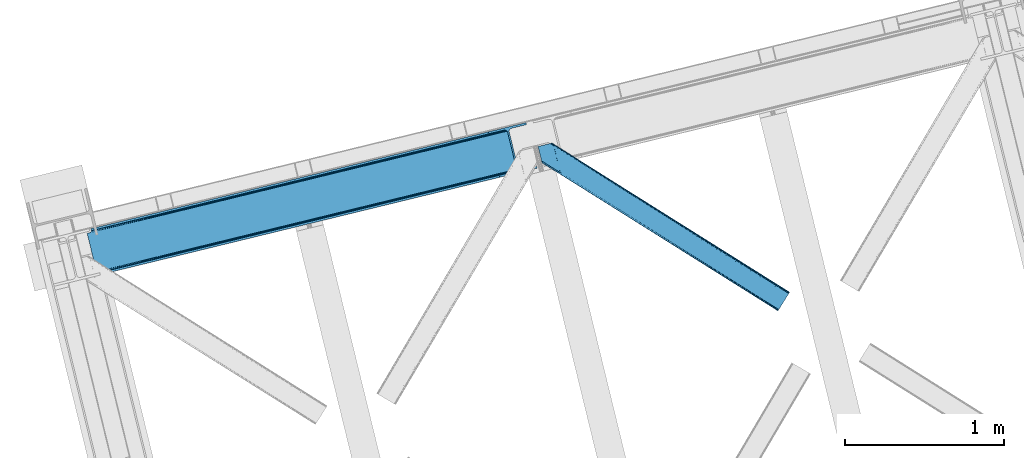
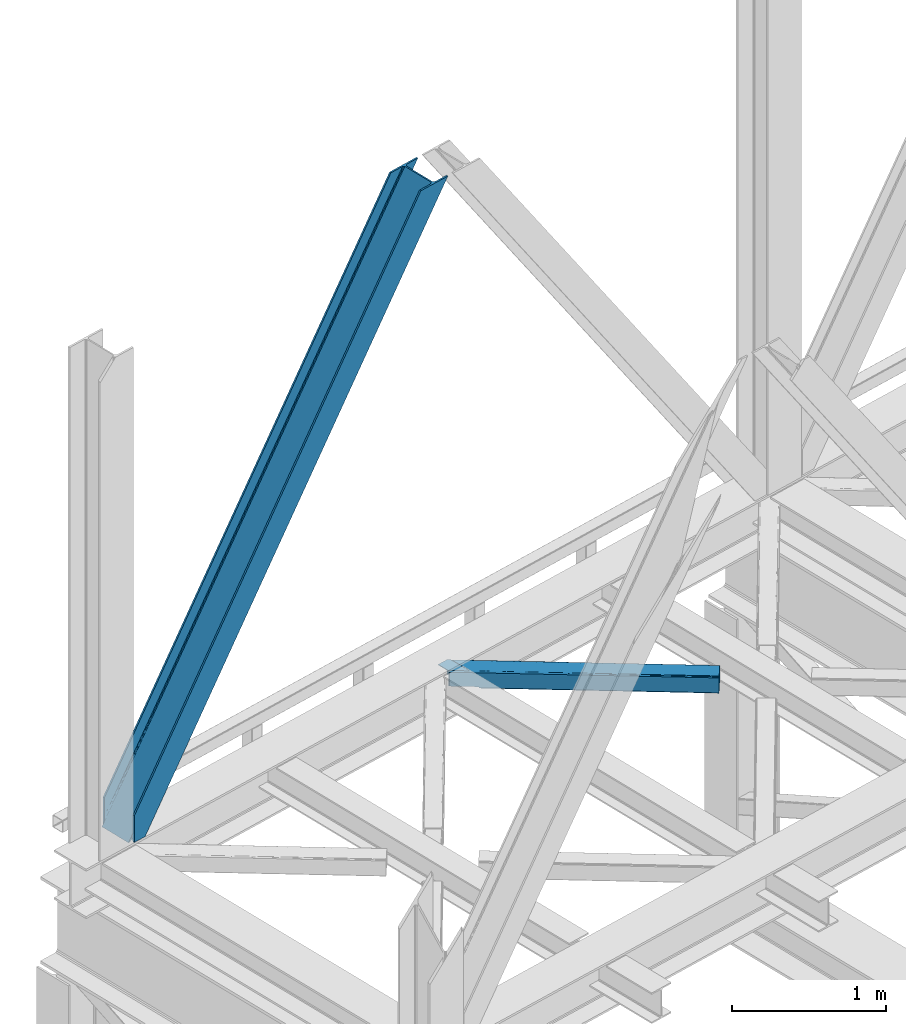
# One storey, part 27 of 92: 2 members.
"""IFC4 building model written with IfcOpenShell, lengths in millimetres."""

from ifc_helpers import new_model, entity, si_unit, converted_unit, derived_unit, direction, frame, origin, place, context, subcontext, project, spatial, triangles, type_object, element, save


model = new_model("IFC4")

# Units and contexts
model_context = context("Model", 3, precision=0.01, world=origin(), true_north=direction((6.12303176911189e-17, 1.0)))
plan_context = context("Plan", 3, precision=0.01, world=origin(), true_north=direction((6.12303176911189e-17, 1.0)))
body_context = subcontext(model_context, "Body", "Model", "MODEL_VIEW")
ifc_project = project(units=[si_unit("LENGTHUNIT", "METRE", prefix="MILLI"), si_unit("AREAUNIT", "SQUARE_METRE"), si_unit("VOLUMEUNIT", "CUBIC_METRE"), converted_unit("PLANEANGLEUNIT", "DEGREE", entity("IfcRatioMeasure", 0.0174532925199433), si_unit("PLANEANGLEUNIT", "RADIAN"), dimensions=[0, 0, 0, 0, 0, 0, 0]), si_unit("MASSUNIT", "GRAM", prefix="KILO"), derived_unit("MASSDENSITYUNIT", [(si_unit("MASSUNIT", "GRAM", prefix="KILO"), 1), (si_unit("LENGTHUNIT", "METRE"), -3)]), derived_unit("MOMENTOFINERTIAUNIT", [(si_unit("LENGTHUNIT", "METRE"), 4)]), si_unit("TIMEUNIT", "SECOND"), si_unit("FREQUENCYUNIT", "HERTZ"), si_unit("THERMODYNAMICTEMPERATUREUNIT", "DEGREE_CELSIUS"), derived_unit("THERMALTRANSMITTANCEUNIT", [(si_unit("MASSUNIT", "GRAM", prefix="KILO"), 1), (si_unit("THERMODYNAMICTEMPERATUREUNIT", "KELVIN"), -1), (si_unit("TIMEUNIT", "SECOND"), -3)]), derived_unit("VOLUMETRICFLOWRATEUNIT", [(si_unit("LENGTHUNIT", "METRE"), 3), (si_unit("TIMEUNIT", "SECOND"), -1)]), derived_unit("MASSFLOWRATEUNIT", [(si_unit("MASSUNIT", "GRAM", prefix="KILO"), 1), (si_unit("TIMEUNIT", "SECOND"), -1)]), derived_unit("ROTATIONALFREQUENCYUNIT", [(si_unit("TIMEUNIT", "SECOND"), -1)]), si_unit("ELECTRICCURRENTUNIT", "AMPERE"), si_unit("ELECTRICVOLTAGEUNIT", "VOLT"), si_unit("POWERUNIT", "WATT"), si_unit("FORCEUNIT", "NEWTON", prefix="KILO"), si_unit("ILLUMINANCEUNIT", "LUX"), si_unit("LUMINOUSFLUXUNIT", "LUMEN"), si_unit("LUMINOUSINTENSITYUNIT", "CANDELA"), derived_unit("USERDEFINED", [(si_unit("MASSUNIT", "GRAM", prefix="KILO"), -1), (si_unit("LENGTHUNIT", "METRE"), -2), (si_unit("TIMEUNIT", "SECOND"), 3), (si_unit("LUMINOUSFLUXUNIT", "LUMEN"), 1)]), derived_unit("LINEARVELOCITYUNIT", [(si_unit("LENGTHUNIT", "METRE"), 1), (si_unit("TIMEUNIT", "SECOND"), -1)]), si_unit("PRESSUREUNIT", "PASCAL"), derived_unit("USERDEFINED", [(si_unit("LENGTHUNIT", "METRE"), -2), (si_unit("MASSUNIT", "GRAM", prefix="KILO"), 1), (si_unit("TIMEUNIT", "SECOND"), -2)]), derived_unit("LINEARFORCEUNIT", [(si_unit("MASSUNIT", "GRAM", prefix="KILO"), 1), (si_unit("LENGTHUNIT", "METRE"), 1), (si_unit("TIMEUNIT", "SECOND"), -2), (si_unit("LENGTHUNIT", "METRE"), -1)]), derived_unit("PLANARFORCEUNIT", [(si_unit("MASSUNIT", "GRAM", prefix="KILO"), 1), (si_unit("LENGTHUNIT", "METRE"), 1), (si_unit("TIMEUNIT", "SECOND"), -2), (si_unit("LENGTHUNIT", "METRE"), -2)])], contexts=[model_context, plan_context])

# Site, building, storey
site_placement = place(None, origin())
site = spatial("IfcSite", under=ifc_project, at=site_placement, CompositionType="ELEMENT")
building_placement = place(site_placement, origin())
building = spatial("IfcBuilding", under=site, at=building_placement, CompositionType="ELEMENT")
storey_placement = place(building_placement, frame((0.0, 0.0, 15900.0)))
storey = spatial("IfcBuildingStorey", under=building, at=storey_placement, Name="05", CompositionType="ELEMENT", Elevation=15900.0)

# Members
member_type_1 = type_object("IfcMemberType", PredefinedType="BRACE")
member_1_placement = place(storey_placement, frame((-60913.72, 5815.15, 3685.0)))
element("IfcMember", 1, at=member_1_placement, inside=storey, type_object=member_type_1, ObjectType="Steel Vertical Brace", PredefinedType="BRACE", context=body_context, shape_type="Tessellation", body=[
    triangles([(58.5685180664004, 23.1980026245119, 0.0), (60.4660766601519, 15.4258026123052, 0.0), (59.1080200195283, 16.2391250610353, 0.781347656247817), (58.9684936523408, 15.0607086181644, 1.0697021484375), (78.1673217773423, 19.7406555175785, 8.06229858398365), (78.1673217773423, 19.7406555175785, 29.5563354492188), (72.7350952148408, 18.4163177490236, 0.0), (500.415966796871, 117.80269317627, 660.427130126951), (82.4554321289033, 19.9237838745121, 36.4024291992173), (86.4830932617188, 18.4523620605469, 44.3670593261704), (502.150744628903, 124.235440063477, 658.201684570311), (88.0643920898438, 17.2873168945316, 48.5435485839844), (2700.97932128906, 660.223072814942, 3921.00020141601), (2700.96536865235, 667.310430908204, 3921.00020141601), (2273.77749023437, 563.178996276855, 3287.10633544922), (2274.31699218749, 556.220118713379, 3287.88535766601), (2697.74696044921, 653.425231933594, 3921.00020141601), (2272.58686523437, 549.787371826172, 3290.11080322265), (2691.76593017578, 647.951147460938, 3921.00020141601), (2268.84755859375, 544.859765625, 3293.43850708008), (2683.94780273437, 644.634489440919, 3921.00020141601), (2263.67113037109, 542.188417053223, 3297.36384887695), (491.5048828125, 110.20373840332, 667.68017578125), (496.68131103515, 112.875086975097, 663.754833984374), (91.1758300781221, 12.6195785522459, 73.6396911621086), (90.6456298828125, 13.899732971192, 61.2474243164033), (89.48291015625, 15.4258026123052, 55.5245178222649), (501.611242675775, 131.194317626953, 657.42033691406), (945.193469238278, 232.231755065918, 1315.62202148437), (944.65396728515, 239.190632629395, 1314.84299926758), (1388.23154296874, 340.227488708496, 1973.04468383789), (1387.69669189453, 347.186366271972, 1972.26333618164), (1831.27426757812, 448.223803710937, 2630.46502075195), (1830.7394165039, 455.182681274414, 2629.6836730957), (943.458691406246, 225.799008178711, 1317.84746704101), (1386.50141601562, 333.795323181153, 1975.26780395508), (1829.544140625, 441.79105682373, 2632.68814086914), (939.724035644525, 220.871401977539, 1321.17517089844), (1382.762109375, 328.86771697998, 1978.5955078125), (1825.80483398437, 436.864031982422, 2636.01817016601), (934.547607421875, 218.200053405762, 1325.10051269531), (1377.59033203125, 326.196368408203, 1982.52317504883), (1820.63305664063, 434.192102050782, 2639.94351196289), (91.1758300781221, 12.6195785522459, 210.054620361327), (2592.01387939453, 622.225392150879, 3921.00020141601), (1332.51401367187, 573.558013916016, 1972.26333618164), (2645.78734130859, 893.682078552246, 3921.00020141601), (2218.59946289062, 789.550643920898, 3287.10633544922), (1775.55673828124, 681.554328918457, 2629.6836730957), (889.471289062494, 465.562280273438, 1314.84299926758), (446.433215332028, 357.565965270996, 657.42033691406), (3.39049072265334, 249.569650268555, 0.0), (86.4830932617188, 18.4523620605469, 15.6757873535134), (82.4554321289033, 19.9237838745121, 13.352673339843), (84.3483398437456, 19.4546264648443, 14.892114257811), (88.0643920898438, 17.2873168945316, 15.1293090820291), (91.4595336914063, 11.6585906982427, 0.0), (90.6456298828125, 13.899732971192, 7.3414123535149), (89.6456909179688, 15.5502136230471, 12.4201721191384), (91.4595336914063, 11.6585906982427, 210.119732666015), (91.1153686523394, 12.7904983520511, 0.0), (2595.09276123047, 609.595349121094, 3921.00020141601), (94.3012207031206, 0.0, 210.119732666015), (94.3012207031206, 0.0, 0.0), (189.179150390621, 23.1270767211918, 0.0), (2831.57600097656, 667.239505004883, 3921.00020141601), (94.1663452148423, 13.3486038208011, 0.0), (186.100268554685, 35.7577011108397, 0.0), (2828.49711914062, 679.870129394531, 3921.00020141601), (1411.90916748047, 334.561555480957, 1955.37134399414), (2305.60810546875, 552.41104888916, 3281.5159790039), (1858.76096191406, 443.486302185059, 2618.4424987793), (2736.56319580078, 657.460450744629, 3921.00020141601), (965.057373046875, 225.637390136719, 1292.29786376953), (518.205578613277, 116.712643432617, 629.226708984374), (512.382678222653, 116.703341674805, 633.152050781249), (72.1351318359375, 19.4703231811527, 0.0), (502.299572753902, 124.272065734864, 638.705200195313), (506.796972656244, 119.357830810547, 636.479754638669), (499.574157714844, 130.697836303711, 639.484222412109), (2728.0939453125, 656.806420898438, 3921.00020141601), (2299.78520507812, 552.401165771485, 3285.44132080078), (2720.26651611328, 658.914431762695, 3921.00020141601), (2294.19949951171, 555.05623626709, 3288.7690246582), (2714.26688232422, 663.462991333008, 3921.00020141601), (2289.70209960937, 559.969889831543, 3290.99447021484), (2711.01591796875, 669.76028137207, 3921.00020141601), (2286.97668457031, 566.395660400391, 3291.77349243164), (68.6190673828096, 25.6478530883787, 0.0), (959.234472656244, 225.628088378907, 1296.22320556641), (1406.08626708984, 334.552253723145, 1959.29668579101), (1852.93341064453, 443.477000427246, 2622.37016601562), (953.648767089842, 228.282577514648, 1299.55323486328), (1400.50056152343, 337.20732421875, 1962.62438964844), (1847.34770507812, 446.131489562988, 2625.69786987305), (949.1513671875, 233.196812438965, 1301.77635498047), (1396.00316162109, 342.120977783204, 1964.84983520508), (1842.85030517578, 451.045724487305, 2627.92098999023), (946.425952148435, 239.622583007813, 1302.55770263672), (1393.27774658203, 348.546748352051, 1965.62885742187), (1840.12489013671, 457.471495056153, 2628.70233764648), (1784.94686279297, 683.843142700195, 2628.70233764648), (1338.09506835937, 574.918395996094, 1965.62885742187), (2655.837890625, 896.131929016114, 3921.00020141601), (2231.79865722656, 792.767308044434, 3291.77349243164), (891.243273925778, 465.994230651856, 1302.55770263672), (444.396130371089, 357.069483947754, 639.484222412109), (13.4410400390625, 252.019500732422, 0.0), (1.49293212890188, 257.342431640625, 0.0), (13.7154418945283, 259.120811462402, 0.0), (13.7619506835908, 260.332946777344, 0.0), (0.665075683587929, 255.996002197266, 0.781347656247817), (0.0, 256.977337646485, 1.0697021484375), (19.1941772460923, 261.656703186035, 8.06229858398365), (19.1941772460923, 261.656703186035, 29.5563354492188), (439.210400390621, 368.90597076416, 660.427130126951), (433.624694824219, 371.560459899903, 663.754833984374), (27.5890136718735, 272.585105895996, 61.2474243164033), (27.4587890624971, 270.661386108399, 54.4989990234353), (443.707800292963, 363.991735839844, 658.201684570311), (23.0869628906221, 263.467639160156, 36.4024291992173), (26.5565185546875, 268.183049011231, 48.2714721679658), (25.9891113281192, 266.62907409668, 44.3670593261704), (427.797143554686, 371.55115814209, 667.68017578125), (27.4680908203081, 273.966998291015, 73.6396911621086), (2628.70931396484, 906.635939025879, 3921.00020141601), (2620.24006347656, 905.981909179688, 3921.00020141601), (2205.79094238281, 803.545138549805, 3293.43850708008), (2199.96804199219, 803.535836791993, 3297.36384887695), (2636.53674316406, 904.528509521485, 3921.00020141601), (2211.37664794922, 800.890649414063, 3290.11080322265), (2642.53637695313, 899.979949951172, 3921.00020141601), (2215.87404785156, 795.976414489746, 3287.88535766601), (876.662768554685, 479.556774902344, 1321.17517089844), (870.839868164061, 479.547473144531, 1325.10051269531), (1319.70549316406, 587.552508544922, 1978.5955078125), (1313.88259277344, 587.543788146972, 1982.52317504883), (1762.74821777343, 695.548823547363, 2636.01817016601), (1756.92531738281, 695.539521789551, 2639.94351196289), (882.248474121094, 476.902285766601, 1317.84746704101), (1325.29119873047, 584.89801940918, 1975.26780395508), (1768.33392333984, 692.894334411621, 2632.68814086914), (886.750524902338, 471.988050842286, 1315.62202148437), (1329.78859863281, 579.984365844727, 1973.04468383789), (1772.83132324219, 687.980099487305, 2630.46502075195), (2528.31079101563, 883.572811889649, 3921.00020141601), (27.4680908203081, 273.966998291015, 210.054620361327), (449.326062011714, 375.38871459961, 633.152050781249), (445.591406249994, 370.461108398437, 636.479754638669), (26.8541748046846, 268.390594482422, 15.1293090820291), (27.4587890624971, 270.661386108399, 12.4201721191384), (454.502490234372, 378.060063171387, 629.226708984374), (27.5890136718735, 272.585105895996, 7.3414123535149), (30.4586059570283, 274.695442199707, 0.0), (443.856628417969, 364.02836151123, 638.705200195313), (25.9891113281192, 266.62907409668, 15.6757873535134), (23.0869628906221, 263.467639160156, 13.352673339843), (24.556640625, 264.76000213623, 14.8944396972656), (2655.82393798828, 903.219287109375, 3921.00020141601), (2231.25915527344, 799.726766967774, 3290.99447021484), (2659.05629882812, 910.017127990723, 3921.00020141601), (2232.98928222656, 806.159513854981, 3288.7690246582), (2665.03732910156, 915.491212463379, 3921.00020141601), (2236.72858886718, 811.08653869629, 3285.44132080078), (2672.85545654297, 918.807870483399, 3921.00020141601), (2241.90501708984, 813.757887268067, 3281.5159790039), (27.4959960937485, 273.787358093262, 0.0), (890.70842285156, 472.953108215333, 1301.77635498047), (1337.56021728515, 581.877854919434, 1964.84983520508), (1784.40736083984, 690.802020263672, 2627.92098999023), (892.438549804683, 479.38585510254, 1299.55323486328), (1339.29034423828, 588.310020446777, 1962.62438964844), (1786.14213867187, 697.234767150879, 2625.69786987305), (896.177856445313, 484.312879943848, 1296.22320556641), (1343.0296508789, 593.23762664795, 1959.29668579101), (1789.87679443359, 702.161791992187, 2622.37016601562), (901.349633789061, 486.984809875488, 1292.29786376953), (1348.20142822265, 595.908975219727, 1955.37134399414), (1795.05322265625, 704.833721923828, 2618.4424987793), (27.2774047851563, 274.948915100098, 0.0), (27.2774047851563, 274.948915100098, 210.119732666015), (2525.23190917969, 896.202854919434, 3921.00020141601), (24.4357177734346, 286.60750579834, 210.119732666015), (24.4357177734346, 286.60750579834, 0.0), (2761.71049804687, 953.847592163086, 3921.00020141601), (2764.78937988281, 941.216967773437, 3921.00020141601), (119.313647460935, 309.735163879394, 0.0), (122.392529296871, 297.105120849609, 0.0)], [[1, 2, 3], [4, 3, 2], [5, 4, 2], [4, 5, 6], [2, 7, 5], [8, 9, 10], [11, 3, 6], [6, 8, 11], [6, 9, 8], [3, 4, 6], [10, 12, 8], [13, 14, 15], [15, 16, 13], [17, 13, 16], [16, 18, 17], [19, 17, 18], [18, 20, 19], [21, 19, 20], [20, 22, 21], [23, 24, 25], [26, 25, 24], [26, 8, 27], [26, 24, 8], [12, 27, 8], [11, 28, 3], [1, 3, 28], [29, 30, 28], [28, 11, 29], [31, 32, 30], [30, 29, 31], [33, 34, 32], [32, 31, 33], [16, 15, 34], [34, 33, 16], [35, 29, 11], [11, 8, 35], [36, 31, 29], [29, 35, 36], [37, 33, 31], [31, 36, 37], [18, 16, 33], [33, 37, 18], [38, 35, 24], [8, 24, 35], [39, 36, 38], [35, 38, 36], [40, 37, 39], [36, 39, 37], [20, 18, 40], [37, 40, 18], [41, 38, 24], [24, 23, 41], [42, 39, 38], [38, 41, 42], [43, 40, 39], [39, 42, 43], [22, 20, 43], [40, 43, 20], [42, 44, 45], [45, 22, 43], [22, 45, 21], [43, 42, 45], [44, 42, 41], [41, 23, 44], [25, 44, 23], [34, 46, 32], [14, 47, 48], [49, 15, 48], [46, 34, 49], [48, 15, 14], [49, 34, 15], [32, 50, 30], [50, 51, 28], [50, 32, 46], [52, 1, 51], [50, 28, 30], [51, 1, 28], [53, 10, 9], [9, 54, 55], [56, 27, 12], [56, 12, 10], [10, 53, 56], [57, 26, 58], [58, 26, 27], [27, 59, 58], [57, 60, 25], [44, 25, 60], [25, 26, 57], [58, 61, 57], [56, 59, 27], [9, 55, 53], [54, 9, 6], [6, 5, 54], [62, 60, 63], [62, 45, 60], [44, 60, 45], [64, 63, 60], [60, 57, 64], [62, 65, 66], [65, 62, 63], [64, 65, 63], [65, 67, 64], [67, 65, 68], [61, 57, 67], [57, 64, 67], [69, 66, 68], [65, 68, 66], [70, 69, 68], [71, 69, 72], [71, 73, 69], [70, 72, 69], [68, 74, 70], [75, 74, 68], [68, 67, 75], [76, 59, 56], [76, 58, 59], [77, 78, 5], [78, 55, 54], [78, 53, 55], [54, 5, 78], [5, 7, 77], [78, 79, 56], [56, 53, 78], [80, 78, 77], [67, 61, 58], [76, 75, 58], [67, 58, 75], [81, 73, 71], [71, 82, 81], [83, 81, 82], [82, 84, 83], [85, 83, 84], [84, 86, 85], [87, 85, 86], [86, 88, 87], [77, 89, 80], [56, 79, 76], [90, 74, 76], [75, 76, 74], [91, 70, 90], [74, 90, 70], [92, 72, 91], [70, 91, 72], [82, 71, 92], [72, 92, 71], [93, 90, 76], [76, 79, 93], [94, 91, 90], [90, 93, 94], [95, 92, 91], [91, 94, 95], [84, 82, 92], [92, 95, 84], [96, 93, 78], [79, 78, 93], [97, 94, 93], [93, 96, 97], [98, 95, 94], [94, 97, 98], [86, 84, 95], [95, 98, 86], [99, 96, 80], [78, 80, 96], [100, 97, 99], [96, 99, 97], [101, 98, 100], [97, 100, 98], [88, 86, 101], [98, 101, 86], [102, 100, 103], [104, 87, 88], [101, 105, 88], [100, 102, 101], [88, 105, 104], [101, 102, 105], [103, 99, 106], [99, 80, 107], [99, 103, 100], [89, 108, 80], [99, 107, 106], [80, 108, 107], [109, 108, 110], [1, 89, 108], [1, 108, 52], [1, 2, 89], [109, 52, 108], [7, 77, 2], [77, 89, 2], [110, 111, 109], [109, 52, 112], [112, 113, 109], [113, 114, 109], [113, 115, 114], [111, 109, 114], [116, 117, 118], [118, 119, 116], [120, 121, 115], [115, 112, 120], [115, 113, 112], [120, 116, 122], [122, 123, 120], [123, 121, 120], [119, 122, 116], [117, 124, 125], [125, 118, 117], [126, 127, 128], [129, 128, 127], [130, 126, 131], [128, 131, 126], [132, 130, 133], [131, 133, 130], [47, 132, 48], [133, 48, 132], [134, 135, 124], [124, 117, 134], [136, 137, 134], [135, 134, 137], [138, 139, 136], [137, 136, 139], [128, 129, 139], [139, 138, 128], [140, 134, 117], [117, 116, 140], [141, 136, 134], [134, 140, 141], [142, 138, 136], [136, 141, 142], [131, 128, 138], [138, 142, 131], [143, 140, 120], [116, 120, 140], [144, 141, 143], [140, 143, 141], [145, 142, 144], [141, 144, 142], [133, 131, 145], [142, 145, 131], [51, 120, 112], [112, 52, 51], [50, 143, 51], [120, 51, 143], [46, 144, 50], [143, 50, 144], [49, 145, 46], [144, 46, 145], [48, 133, 49], [145, 49, 133], [146, 147, 137], [137, 139, 146], [139, 129, 146], [127, 146, 129], [135, 137, 147], [147, 125, 124], [124, 135, 147], [148, 149, 150], [150, 151, 148], [152, 148, 153], [153, 154, 152], [107, 108, 110], [155, 156, 150], [155, 110, 114], [114, 157, 155], [157, 158, 155], [158, 156, 155], [110, 111, 114], [150, 149, 155], [110, 155, 107], [159, 104, 160], [105, 160, 104], [161, 159, 162], [160, 162, 159], [163, 161, 164], [162, 164, 161], [165, 163, 166], [164, 166, 163], [153, 167, 154], [151, 153, 148], [168, 106, 107], [107, 155, 168], [169, 103, 106], [106, 168, 169], [170, 102, 103], [103, 169, 170], [160, 105, 102], [102, 170, 160], [171, 168, 155], [155, 149, 171], [172, 169, 171], [168, 171, 169], [173, 170, 172], [169, 172, 170], [162, 160, 173], [170, 173, 160], [174, 171, 148], [149, 148, 171], [175, 172, 174], [171, 174, 172], [176, 173, 175], [172, 175, 173], [164, 162, 176], [173, 176, 162], [177, 174, 148], [148, 152, 177], [178, 175, 174], [174, 177, 178], [179, 176, 175], [175, 178, 179], [166, 164, 176], [176, 179, 166], [156, 158, 121], [121, 123, 156], [150, 156, 123], [123, 122, 150], [119, 151, 150], [118, 153, 119], [151, 119, 153], [180, 167, 153], [153, 125, 180], [181, 180, 125], [125, 147, 181], [118, 125, 153], [122, 119, 150], [158, 157, 121], [121, 157, 115], [114, 115, 157], [182, 181, 146], [181, 182, 183], [181, 147, 146], [180, 181, 184], [183, 184, 181], [47, 14, 104], [17, 19, 81], [21, 62, 66], [45, 62, 21], [19, 21, 73], [14, 13, 85], [13, 17, 83], [130, 163, 126], [182, 127, 185], [127, 126, 165], [182, 146, 127], [130, 132, 161], [132, 47, 159], [104, 14, 87], [73, 81, 19], [85, 13, 83], [81, 83, 17], [85, 87, 14], [66, 73, 21], [66, 69, 73], [165, 126, 163], [161, 132, 159], [104, 159, 47], [161, 163, 130], [165, 185, 127], [185, 165, 186], [187, 154, 184], [154, 187, 188], [167, 180, 154], [180, 184, 154], [182, 187, 183], [182, 185, 187], [187, 184, 183], [186, 178, 188], [179, 186, 166], [186, 179, 178], [186, 165, 166], [177, 188, 178], [154, 188, 152], [177, 152, 188], [185, 186, 187], [188, 187, 186]]),
])
member_type_2 = type_object("IfcMemberType", PredefinedType="BRACE")
member_2_placement = place(storey_placement, frame((-58076.85, 5584.42, 3511.0)))
element("IfcMember", 2, at=member_2_placement, inside=storey, type_object=member_type_2, ObjectType="Steel Horizontal Brace", PredefinedType="BRACE", context=body_context, shape_type="Tessellation", body=[
    triangles([(207.717553710943, 837.213432312012, 0.0), (172.040661621097, 983.576010131836, 0.0), (1573.7830078125, 103.755294799805, 0.0), (1517.96315917969, 14.8223510742191, 0.0), (1583.08941650391, 118.577645874024, 17.5000946044929), (1582.37783203126, 117.449226379395, 10.8028289794929), (166.547973632813, 1006.1130065918, 10.8028289794929), (166.096838378908, 1007.96986999512, 17.5000946044929), (1580.36400146485, 114.236631774902, 5.12526855468968), (167.83626708985, 1000.82495727539, 5.12526855468968), (1577.34558105469, 109.42762298584, 1.33247680664135), (169.766381835943, 992.910905456543, 1.33247680664135), (1514.40523681641, 9.15002288818323, 1.33247680664135), (202.587634277348, 832.527671813965, 1.33247680664135), (208.508203125006, 833.971769714355, 0.155804443362285), (1511.38681640625, 4.34159545898456, 5.12526855468968), (194.895080566406, 830.652786254883, 5.12526855468968), (1509.36833496094, 1.12841949462927, 10.8028289794929), (189.755859375, 829.399955749512, 10.8028289794929), (1508.66140136719, 0.0, 17.5000946044929), (187.951318359381, 828.959866333008, 17.5000946044929), (204.378222656254, 832.964854431152, 12.1260040283232), (208.508203125006, 833.971769714355, 9.69243164062573), (199.652929687501, 831.812017822265, 17.9802978515654), (198.425097656254, 831.512617492675, 19.4999725341804), (187.951318359381, 828.959866333008, 19.4999725341804), (25.3100830078183, 931.043751525879, 19.4999725341804), (22.6823364257871, 941.818675231933, 19.4999725341804), (1508.66140136719, 0.0, 122.500662231447), (25.3100830078183, 931.043751525879, 122.500662231447), (1521.68386230469, 20.7510589599606, 6.99957275390625), (205.340954589847, 846.970976257324, 6.99957275390625), (207.559423828126, 837.873275756836, 8.88434143066479), (1518.12593994141, 15.0787307739256, 8.3320495605476), (1515.10751953125, 10.2703033447269, 12.1260040283232), (1513.08903808594, 7.05712738037073, 17.8035644531265), (1512.38210449219, 5.92870788574237, 24.4996673583992), (22.9288330078125, 940.801295471191, 24.4996673583992), (174.421911621095, 973.818466186523, 6.99957275390625), (1570.0623046875, 97.8265869140623, 6.99957275390625), (168.971081542972, 996.182798767089, 17.8803039550803), (170.217517089848, 991.067413330078, 12.1260040283232), (172.142980957033, 983.15336151123, 8.3320495605476), (168.836206054693, 996.73392791748, 18.5000335693367), (166.096838378908, 1007.96986999512, 18.5000335693367), (1512.38210449219, 5.92870788574237, 115.501089477541), (22.9288330078125, 940.801295471191, 115.501089477541), (1521.68386230469, 20.7510589599606, 133.000021362306), (1518.12593994141, 15.0787307739256, 131.667544555665), (19.2592895507842, 955.860260009766, 131.667544555665), (16.9850097656308, 965.195155334472, 133.000021362306), (1515.10751953125, 10.2703033447269, 127.87475280762), (21.1894042968779, 947.946208190918, 127.87475280762), (1513.08903808594, 7.05712738037073, 122.196029663086), (22.4776977539077, 942.658158874512, 122.196029663086), (168.515295410158, 997.028096008301, 18.7407165527366), (165.808483886722, 1008.15009155273, 18.736065673831), (168.171130371098, 997.346099853516, 19.0000030517585), (165.487573242193, 1008.35124206543, 19.0000030517585), (167.826965332031, 997.66410369873, 19.2592895507842), (165.166662597658, 1008.55181121826, 19.2639404296897), (167.506054687503, 997.958271789551, 19.4999725341804), (164.878308105472, 1008.73261413574, 19.4999725341804), (78.2928955078169, 1053.95369110107, 19.4999725341804), (88.7666748046904, 1056.50644226074, 19.4999725341804), (24.8542968750044, 932.900614929199, 129.197927856447), (23.5660034179746, 938.188664245606, 134.874325561526), (22.1242309570371, 944.113883972168, 137.999716186525), (0.0, 1034.86880950928, 137.999716186525), (0.0, 1034.86880950928, 133.000021362306), (1583.08941650391, 118.577645874024, 122.500662231447), (88.7666748046904, 1056.50644226074, 122.500662231447), (1578.65712890626, 111.520518493652, 17.8035644531265), (1579.36871337891, 112.648937988281, 24.4996673583992), (79.2835327148496, 1054.19495544434, 24.4996673583992), (1573.62487792969, 103.498915100097, 8.3320495605476), (1576.64329833985, 108.307342529297, 12.1260040283232), (64.647216796875, 1050.62714996338, 131.667544555665), (55.5733520507856, 1048.41507568359, 133.000021362306), (76.0651245117188, 1053.41011962891, 137.999716186525), (81.8229125976577, 1054.81352233887, 134.874325561526), (72.3397705078169, 1052.50203552246, 127.87475280762), (77.4789916992231, 1053.75486602783, 122.196029663086), (86.962133789064, 1056.06635284424, 129.197927856447), (79.2835327148496, 1054.19495544434, 115.501089477541), (1570.0623046875, 97.8265869140623, 133.000021362306), (1579.36871337891, 112.648937988281, 115.501089477541), (1578.65712890626, 111.520518493652, 122.196029663086), (1576.64329833985, 108.307342529297, 127.87475280762), (1573.62487792969, 103.498915100097, 131.667544555665), (1582.37783203126, 117.449226379395, 129.197927856447), (1580.36400146485, 114.236631774902, 134.874325561526), (1577.34558105469, 109.42762298584, 138.667117309571), (1573.7830078125, 103.755294799805, 139.999594116212), (1517.96315917969, 14.8223510742191, 139.999594116212), (1514.40523681641, 9.15002288818323, 138.667117309571), (1511.38681640625, 4.34159545898456, 134.874325561526), (1509.36833496094, 1.12841949462927, 129.197927856447), (98.1940063476577, 1039.52085113525, 137.999716186525), (139.391491699222, 870.509074401855, 137.999716186525), (137.847399902348, 881.070639038086, 139.999594116212), (139.828674316406, 872.942646789551, 138.999655151369), (140.051916503908, 871.778764343262, 138.667117309571), (139.805419921875, 870.421870422363, 138.076455688479), (139.921691894531, 871.056134033203, 138.353182983399), (98.7056030273452, 1039.02378845215, 138.076455688479), (99.5985717773438, 1036.93496246338, 138.634561157229), (99.1985961914106, 1037.87211456299, 138.383413696291), (100.184582519534, 1035.56120910644, 138.999655151369), (102.1658569336, 1027.43379821777, 139.999594116212), (140.037963867188, 871.692723083496, 138.629910278323)], [[1, 2, 3], [3, 4, 1], [5, 6, 7], [7, 8, 5], [6, 9, 10], [10, 7, 6], [9, 11, 12], [12, 10, 9], [11, 3, 2], [2, 12, 11], [13, 14, 15], [15, 4, 13], [15, 1, 4], [13, 16, 14], [17, 14, 16], [16, 18, 17], [19, 17, 18], [18, 20, 19], [21, 19, 20], [22, 23, 14], [22, 14, 17], [17, 19, 24], [23, 15, 14], [24, 22, 17], [19, 21, 25], [26, 25, 21], [19, 25, 24], [27, 28, 25], [25, 26, 27], [26, 29, 30], [20, 26, 21], [26, 20, 29], [26, 30, 27], [31, 32, 33], [34, 33, 23], [23, 35, 34], [23, 22, 35], [36, 35, 22], [37, 36, 24], [24, 25, 37], [37, 25, 38], [28, 38, 25], [22, 24, 36], [33, 34, 31], [39, 32, 40], [31, 40, 32], [41, 7, 10], [10, 42, 41], [12, 42, 10], [42, 12, 43], [7, 44, 8], [45, 8, 44], [7, 41, 44], [43, 12, 2], [33, 32, 1], [1, 39, 2], [39, 1, 32], [15, 33, 1], [39, 43, 2], [23, 33, 15], [46, 37, 38], [38, 47, 46], [48, 49, 50], [50, 51, 48], [49, 52, 53], [53, 50, 49], [52, 54, 55], [55, 53, 52], [54, 46, 47], [47, 55, 54], [45, 44, 56], [56, 57, 45], [57, 56, 58], [58, 59, 57], [59, 58, 60], [60, 61, 59], [61, 60, 62], [62, 63, 61], [64, 65, 63], [63, 62, 64], [47, 27, 30], [66, 55, 30], [55, 66, 67], [55, 47, 30], [38, 27, 47], [28, 27, 38], [53, 55, 67], [68, 51, 50], [51, 68, 69], [69, 70, 51], [50, 53, 68], [68, 53, 67], [5, 45, 71], [8, 45, 5], [45, 72, 71], [72, 45, 57], [72, 57, 59], [59, 61, 72], [63, 72, 61], [72, 63, 65], [73, 41, 42], [74, 75, 62], [62, 73, 74], [56, 73, 58], [56, 44, 73], [73, 60, 58], [73, 62, 60], [44, 41, 73], [75, 64, 62], [40, 76, 39], [43, 39, 76], [76, 77, 43], [42, 43, 77], [42, 77, 73], [78, 79, 80], [81, 82, 80], [78, 80, 82], [83, 81, 84], [79, 69, 80], [79, 70, 69], [83, 82, 81], [72, 85, 83], [85, 72, 65], [75, 65, 64], [65, 75, 85], [72, 83, 84], [51, 79, 86], [79, 51, 70], [86, 48, 51], [74, 87, 85], [85, 75, 74], [87, 88, 85], [83, 85, 88], [88, 89, 83], [82, 83, 89], [89, 90, 82], [78, 82, 90], [90, 86, 78], [79, 78, 86], [91, 89, 88], [87, 5, 71], [91, 88, 71], [91, 92, 89], [88, 87, 71], [89, 92, 93], [86, 94, 95], [94, 90, 93], [90, 94, 86], [90, 89, 93], [6, 77, 9], [74, 5, 87], [5, 73, 6], [73, 5, 74], [6, 73, 77], [3, 40, 4], [11, 9, 77], [77, 76, 11], [76, 40, 3], [3, 11, 76], [52, 96, 97], [95, 48, 86], [95, 49, 48], [49, 95, 96], [52, 49, 96], [46, 29, 20], [98, 54, 52], [97, 98, 52], [54, 98, 29], [46, 54, 29], [13, 35, 16], [4, 40, 31], [31, 34, 4], [34, 35, 13], [13, 4, 34], [18, 16, 35], [20, 37, 46], [36, 20, 18], [20, 36, 37], [36, 18, 35], [80, 68, 99], [80, 69, 68], [100, 99, 68], [95, 101, 102], [102, 96, 95], [102, 103, 96], [97, 104, 100], [100, 67, 97], [100, 68, 67], [96, 105, 104], [96, 103, 105], [104, 97, 96], [29, 98, 30], [66, 30, 98], [98, 97, 66], [67, 66, 97], [92, 81, 106], [106, 93, 92], [107, 93, 108], [106, 108, 93], [81, 80, 99], [107, 94, 93], [107, 109, 94], [109, 110, 94], [92, 91, 84], [84, 81, 92], [91, 71, 72], [72, 84, 91], [110, 101, 94], [95, 94, 101], [111, 102, 109], [109, 107, 111], [107, 108, 104], [108, 106, 104], [110, 109, 101], [102, 101, 109]]),
])

save(model, "model.ifc")
